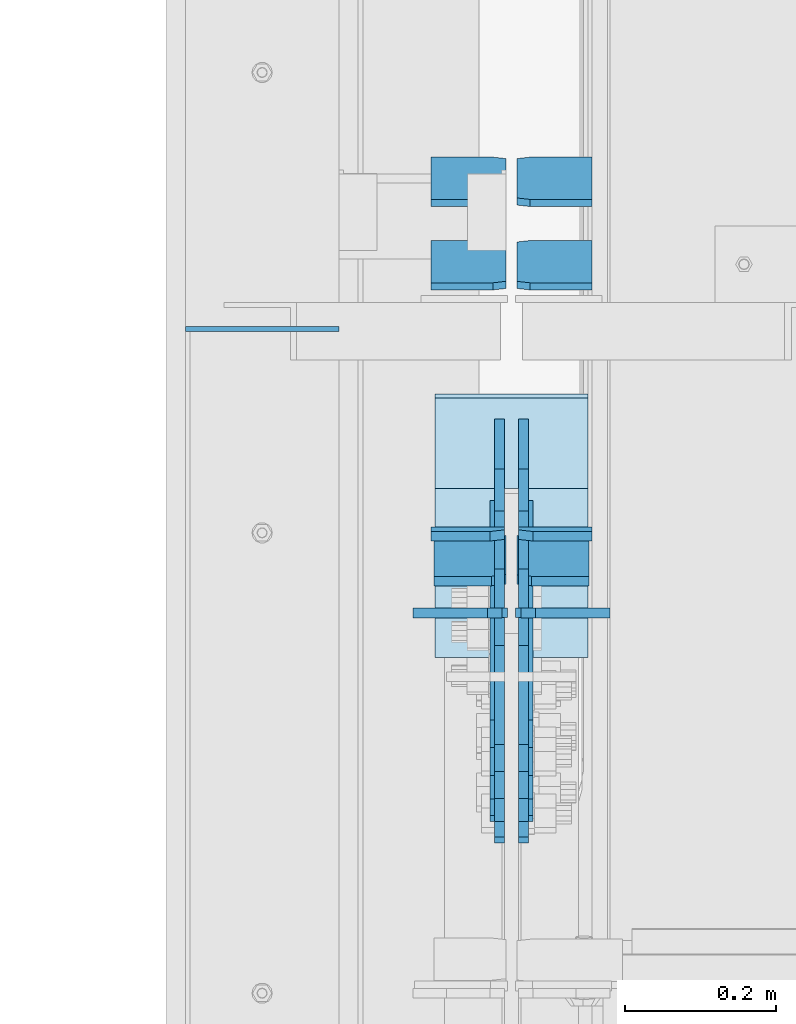
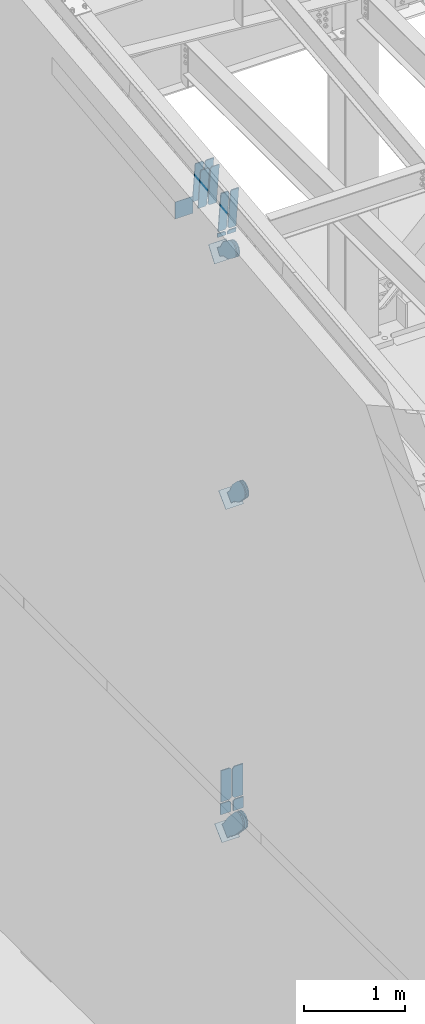
# One storey, part 1014 of 1179: 22 plates, 12 elements without a shape of their own.
"""IFC2X3 building model written with IfcOpenShell, lengths in millimetres."""

from ifc_helpers import new_model, si_unit, frame, origin_with_axes, place, context, subcontext, project, spatial, faceted_brep, material, type_object, element, aggregate, save


model = new_model("IFC2X3")

# Units and contexts
model_context = context("Model", 3, precision=1e-05, world=origin_with_axes())
body_context = subcontext(model_context, "Body", "Model", "MODEL_VIEW")
ifc_project = project(units=[si_unit("LENGTHUNIT", "METRE", prefix="MILLI"), si_unit("AREAUNIT", "SQUARE_METRE"), si_unit("VOLUMEUNIT", "CUBIC_METRE"), si_unit("MASSUNIT", "GRAM", prefix="KILO"), si_unit("TIMEUNIT", "SECOND"), si_unit("PLANEANGLEUNIT", "RADIAN"), si_unit("SOLIDANGLEUNIT", "STERADIAN"), si_unit("THERMODYNAMICTEMPERATUREUNIT", "DEGREE_CELSIUS"), si_unit("LUMINOUSINTENSITYUNIT", "LUMEN")], contexts=[model_context])

# Site, building, storey
site_placement = place(None, origin_with_axes())
site = spatial("IfcSite", under=ifc_project, at=site_placement, CompositionType="ELEMENT")
building_placement = place(site_placement, origin_with_axes())
building = spatial("IfcBuilding", under=site, at=building_placement, Name="Undefined", CompositionType="ELEMENT")
storey_placement = place(building_placement, origin_with_axes())
storey = spatial("IfcBuildingStorey", under=building, at=storey_placement, Name="Undefined", CompositionType="ELEMENT", Elevation=0.0)

# Assembly, plates
assembly_1_placement = place(storey_placement, origin_with_axes())
assembly_1 = element("IfcElementAssembly", 1, at=assembly_1_placement, inside=storey, Name="BEAM", AssemblyPlace="NOTDEFINED", PredefinedType="RIGID_FRAME")
ifc_material_1 = material(Name="STEEL/A572-GR.50")
plate_type_1 = type_object("IfcPlateType", PredefinedType="NOTDEFINED")
plate_1_placement = place(assembly_1_placement, frame((534.193750000002, 15956.040134361, 10522.6825112372), z_axis=(0.0, -0.112284087038017, 0.993676146336441), x_axis=(-1.0, 0.0, 0.0)))
plate_1 = element("IfcPlate", 2, at=plate_1_placement, type_object=plate_type_1, material=ifc_material_1, Name="PLATE", context=body_context, shape_type="Brep", body=[
    faceted_brep([(0.0, -6.34999999999854, 0.0), (0.0, -6.35000000019863, 498.474999998592), (0.0, 6.34999999979118, 498.474999998596), (0.0, 6.34999999999854, 0.0), (76.2000007629395, -6.35000000019863, 498.474999998592), (76.2000007629395, 6.34999999979118, 498.474999998596), (95.25, -6.350000000195, 479.425000761541), (95.25, 6.34999999980209, 479.425000761548), (95.25, -6.35000000000946, 19.0499992370496), (95.25, 6.34999999998399, 19.0499992370533), (76.2000007629395, -6.35000000000218, 0.0), (76.2000007629395, 6.34999999999491, 3.63797880709171e-12)], [[[0, 1, 2, 3]], [[1, 4, 5, 2]], [[4, 6, 7, 5]], [[6, 8, 9, 7]], [[8, 10, 11, 9]], [[10, 0, 3, 11]], [[5, 7, 9, 11, 3, 2]], [[10, 8, 6, 4, 1, 0]]]),
])
plate_2_placement = place(assembly_1_placement, frame((424.656250000002, 15956.040134361, 10522.6825112372), z_axis=(0.0, -0.112284087038017, 0.993676146336441), x_axis=(-1.0, 0.0, 0.0)))
plate_2 = element("IfcPlate", 3, at=plate_2_placement, type_object=plate_type_1, material=ifc_material_1, Name="PLATE", context=body_context, shape_type="Brep", body=[
    faceted_brep([(0.0, -6.35000000000036, 19.0499999999993), (0.0, -6.350000000195, 479.425000761541), (0.0, 6.34999999980209, 479.425000761548), (0.0, 6.35000000000036, 19.0499999999993), (19.0499992370605, -6.35000000019863, 498.474999998592), (19.0499992370605, 6.34999999979118, 498.474999998596), (95.25, -6.349999999793, 498.474999998598), (95.25, 6.35000000020045, 498.474999998592), (95.25, -6.34999999999309, 1.81898940354586e-12), (95.25, 6.34999999999854, -1.81898940354586e-12), (19.0500000000002, -6.35000000000036, 0.0), (19.0500000000002, 6.35000000000036, 0.0)], [[[0, 1, 2, 3]], [[1, 4, 5, 2]], [[4, 6, 7, 5]], [[6, 8, 9, 7]], [[8, 10, 11, 9]], [[3, 11, 10, 0]], [[5, 7, 9, 11, 3, 2]], [[10, 8, 6, 4, 1, 0]]]),
])

assembly_2_placement = place(storey_placement, origin_with_axes())
assembly_2 = element("IfcElementAssembly", 4, at=assembly_2_placement, inside=storey, Name="BEAM", AssemblyPlace="NOTDEFINED", PredefinedType="RIGID_FRAME")
plate_type_2 = type_object("IfcPlateType", PredefinedType="NOTDEFINED")
plate_3_placement = place(assembly_2_placement, frame((558.006250000002, 15857.8351561904, 3703.6375), z_axis=(0.0, 0.0, 1.0), x_axis=(-1.0, 0.0, 0.0)))
plate_3 = element("IfcPlate", 5, at=plate_3_placement, type_object=plate_type_2, material=ifc_material_1, Name="PLATE", context=body_context, shape_type="Brep", body=[
    faceted_brep([(0.0, -6.34999999999854, 0.0), (0.0, -6.35000000000036, 377.825012207031), (0.0, 6.35000000000036, 377.825012207031), (0.0, 6.34999999999854, 0.0), (98.4250011444092, -6.35000000000036, 377.825012207031), (98.4250011444092, 6.35000000000036, 377.825012207031), (120.650001525879, -6.35000000000036, 355.600011825562), (120.650001525879, 6.35000000000036, 355.600011825562), (120.650001525879, -6.35000000000036, 22.2250003814697), (120.650001525879, 6.35000000000036, 22.2250003814697), (98.4250011444092, -6.35000000000036, 0.0), (98.4250011444092, 6.35000000000036, 0.0)], [[[0, 1, 2, 3]], [[1, 4, 5, 2]], [[4, 6, 7, 5]], [[6, 8, 9, 7]], [[8, 10, 11, 9]], [[10, 0, 3, 11]], [[5, 7, 9, 11, 3, 2]], [[10, 8, 6, 4, 1, 0]]]),
])
plate_4_placement = place(assembly_2_placement, frame((426.243750000002, 15857.8351561904, 3703.6375), z_axis=(0.0, 0.0, 1.0), x_axis=(-1.0, 0.0, 0.0)))
plate_4 = element("IfcPlate", 6, at=plate_4_placement, type_object=plate_type_2, material=ifc_material_1, Name="PLATE", context=body_context, shape_type="Brep", body=[
    faceted_brep([(0.0, -6.34999999999854, 22.2250003814697), (0.0, -6.34999999999854, 355.600011825562), (0.0, 6.34999999999854, 355.600011825562), (0.0, 6.34999999999854, 22.2250003814697), (22.2250003814697, -6.34999999999854, 377.825012207031), (22.2250003814697, 6.34999999999854, 377.825012207031), (120.650001525879, -6.34999999999854, 377.825012207031), (120.650001525879, 6.34999999999854, 377.825012207031), (120.650001525879, -6.34999999999854, 0.0), (120.650001525879, 6.34999999999854, 0.0), (22.2250003814697, -6.34999999999854, 0.0), (22.2250003814697, 6.34999999999854, 0.0)], [[[0, 1, 2, 3]], [[1, 4, 5, 2]], [[4, 6, 7, 5]], [[6, 8, 9, 7]], [[8, 10, 11, 9]], [[10, 0, 3, 11]], [[5, 7, 9, 11, 3, 2]], [[10, 8, 6, 4, 1, 0]]]),
])

# Assembly, plate
assembly_3_placement = place(storey_placement, origin_with_axes())
assembly_3 = element("IfcElementAssembly", 7, at=assembly_3_placement, inside=storey, AssemblyPlace="NOTDEFINED", PredefinedType="RIGID_FRAME")
ifc_material_2 = material(Name="STEEL/A36")
plate_type_3 = type_object("IfcPlateType", PredefinedType="NOTDEFINED")
plate_5_placement = place(assembly_3_placement, frame((415.925000000002, 16048.2448473155, 10252.7845981471), z_axis=(0.0, -0.591856615182529, -0.80604326624858), x_axis=(0.0, 0.806043266248581, -0.591856615182529)))
plate_5 = element("IfcPlate", 8, at=plate_5_placement, type_object=plate_type_3, material=ifc_material_2, context=body_context, shape_type="Brep", body=[
    faceted_brep([(0.0, -6.34999999999854, 0.0), (-101.600000000211, -6.34999999999854, -44.6881937825565), (-101.600000000211, 6.34999999999854, -44.6881937825565), (0.0, 6.34999999999854, 0.0), (-246.684985848258, -6.34999999999854, -44.6881937827675), (-246.684985848258, 6.34999999999854, -44.6881937827675), (-281.313054102191, -6.34999999999854, -37.800242748639), (-281.313054102191, 6.34999999999854, -37.800242748639), (-310.669312868691, -6.34999999999854, -18.1850177516608), (-310.669312868691, 6.34999999999854, -18.1850177516608), (-330.284537865713, -6.34999999999854, 11.1712410148393), (-330.284537865713, 6.34999999999854, 11.1712410148393), (-337.172488899912, -6.34999999999854, 45.7993031647638), (-337.172488899912, 6.34999999999854, 45.7993031647638), (-330.284537865768, -6.34999999999854, 80.4273714187839), (-330.284537865768, 6.34999999999854, 80.4273714187839), (-310.669312868773, -6.34999999999854, 109.783630185371), (-310.669312868773, 6.34999999999854, 109.783630185371), (-281.313054102271, -6.34999999999854, 129.398855182466), (-281.313054102271, 6.34999999999854, 129.398855182466), (-246.684988899762, -6.34999999999854, 136.286806216707), (-246.684988899762, 6.34999999999854, 136.286806216707), (-101.600000000377, -6.34999999999854, 136.286806216911), (-101.600000000377, 6.34999999999854, 136.286806216911), (-8.18545231595635e-11, -6.34999999999854, 91.5986124346418), (-8.18545231595635e-11, 6.34999999999854, 91.5986124346418), (82.5500000001266, -6.34999999999854, 91.5986124347546), (82.5500000001266, 6.34999999999854, 91.5986124347546), (82.550000000203, -6.34999999999854, 1.2732925824821e-10), (82.550000000203, 6.34999999999854, 1.2732925824821e-10)], [[[0, 1, 2, 3]], [[1, 4, 5, 2]], [[4, 6, 7, 5]], [[6, 8, 9, 7]], [[8, 10, 11, 9]], [[10, 12, 13, 11]], [[12, 14, 15, 13]], [[14, 16, 17, 15]], [[16, 18, 19, 17]], [[18, 20, 21, 19]], [[20, 22, 23, 21]], [[22, 24, 25, 23]], [[24, 26, 27, 25]], [[26, 28, 29, 27]], [[28, 0, 3, 29]], [[5, 7, 9, 11, 13, 15, 17, 19, 21, 23, 25, 27, 29, 3, 2]], [[28, 26, 24, 22, 20, 18, 16, 14, 12, 10, 8, 6, 4, 1, 0]]]),
])
aggregate(assembly_3, [plate_5])

assembly_4_placement = place(storey_placement, origin_with_axes())
assembly_4 = element("IfcElementAssembly", 9, at=assembly_4_placement, inside=storey, AssemblyPlace="NOTDEFINED", PredefinedType="RIGID_FRAME")
plate_6_placement = place(assembly_4_placement, frame((447.675000000002, 16048.2448473155, 10252.7845981471), z_axis=(0.0, -0.591856615182529, -0.80604326624858), x_axis=(0.0, 0.806043266248581, -0.591856615182529)))
plate_6 = element("IfcPlate", 10, at=plate_6_placement, type_object=plate_type_3, material=ifc_material_2, context=body_context, shape_type="Brep", body=[
    faceted_brep([(0.0, -6.34999999999854, 0.0), (-101.600000000211, -6.34999999999854, -44.6881937825565), (-101.600000000211, 6.34999999999854, -44.6881937825565), (0.0, 6.34999999999854, 0.0), (-246.684985848258, -6.34999999999854, -44.6881937827675), (-246.684985848258, 6.34999999999854, -44.6881937827675), (-281.313054102191, -6.34999999999854, -37.800242748639), (-281.313054102191, 6.34999999999854, -37.800242748639), (-310.669312868691, -6.34999999999854, -18.1850177516608), (-310.669312868691, 6.34999999999854, -18.1850177516608), (-330.284537865713, -6.34999999999854, 11.1712410148393), (-330.284537865713, 6.34999999999854, 11.1712410148393), (-337.172488899912, -6.34999999999854, 45.7993031647638), (-337.172488899912, 6.34999999999854, 45.7993031647638), (-330.284537865768, -6.34999999999854, 80.4273714187839), (-330.284537865768, 6.34999999999854, 80.4273714187839), (-310.669312868773, -6.34999999999854, 109.783630185371), (-310.669312868773, 6.34999999999854, 109.783630185371), (-281.313054102271, -6.34999999999854, 129.398855182466), (-281.313054102271, 6.34999999999854, 129.398855182466), (-246.684988899762, -6.34999999999854, 136.286806216707), (-246.684988899762, 6.34999999999854, 136.286806216707), (-101.600000000377, -6.34999999999854, 136.286806216911), (-101.600000000377, 6.34999999999854, 136.286806216911), (-8.18545231595635e-11, -6.34999999999854, 91.5986124346418), (-8.18545231595635e-11, 6.34999999999854, 91.5986124346418), (82.5500000001266, -6.34999999999854, 91.5986124347546), (82.5500000001266, 6.34999999999854, 91.5986124347546), (82.550000000203, -6.34999999999854, 1.2732925824821e-10), (82.550000000203, 6.34999999999854, 1.2732925824821e-10)], [[[0, 1, 2, 3]], [[1, 4, 5, 2]], [[4, 6, 7, 5]], [[6, 8, 9, 7]], [[8, 10, 11, 9]], [[10, 12, 13, 11]], [[12, 14, 15, 13]], [[14, 16, 17, 15]], [[16, 18, 19, 17]], [[18, 20, 21, 19]], [[20, 22, 23, 21]], [[22, 24, 25, 23]], [[24, 26, 27, 25]], [[26, 28, 29, 27]], [[28, 0, 3, 29]], [[5, 7, 9, 11, 13, 15, 17, 19, 21, 23, 25, 27, 29, 3, 2]], [[28, 26, 24, 22, 20, 18, 16, 14, 12, 10, 8, 6, 4, 1, 0]]]),
])
aggregate(assembly_4, [plate_6])

assembly_5_placement = place(storey_placement, origin_with_axes())
assembly_5 = element("IfcElementAssembly", 11, at=assembly_5_placement, inside=storey, Name="BEAM", AssemblyPlace="NOTDEFINED", PredefinedType="RIGID_FRAME")
plate_type_4 = type_object("IfcPlateType", PredefinedType="NOTDEFINED")
plate_7_placement = place(assembly_5_placement, frame((0.0, 16233.775, 10824.825825947), z_axis=(0.0, 0.0, -1.0), x_axis=(1.0, 0.0, 0.0)))
plate_7 = element("IfcPlate", 12, at=plate_7_placement, type_object=plate_type_4, material=ifc_material_2, Name="CAP_PLATE", context=body_context, shape_type="Brep", body=[
    faceted_brep([(0.0, -3.17500000000109, 0.0), (0.0, -3.17499999999927, 204.492999998953), (0.0, 3.17499999999927, 204.492999998953), (0.0, 3.17500000000109, 7.27595761418343e-12), (203.199999999997, -3.17499999999927, 204.492999998953), (203.199999999997, 3.17499999999927, 204.492999998953), (203.199999999997, -3.17499999999927, 3.63797880709171e-12), (203.199999999997, 3.17499999999382, -3.63797880709171e-12)], [[[0, 1, 2, 3]], [[1, 4, 5, 2]], [[4, 6, 7, 5]], [[6, 0, 3, 7]], [[5, 7, 3, 2]], [[6, 4, 1, 0]]]),
])
aggregate(assembly_5, [plate_7])

assembly_6_placement = place(storey_placement, origin_with_axes())
assembly_6 = element("IfcElementAssembly", 13, at=assembly_6_placement, inside=storey, Name="Plate", AssemblyPlace="NOTDEFINED", PredefinedType="RIGID_FRAME")
plate_8_placement = place(assembly_6_placement, frame((330.200000000002, 16024.9852771183, 10086.9957610887), z_axis=(0.0, 0.591856615182528, 0.806043266248581), x_axis=(1.0, 0.0, 0.0)))
plate_8 = element("IfcPlate", 14, at=plate_8_placement, type_object=plate_type_4, material=ifc_material_2, Name="Plate", context=body_context, shape_type="Brep", body=[
    faceted_brep([(0.0, -3.17500000000109, 0.0), (0.0, -3.17500000000291, 203.200000000368), (0.0, 3.17499999998836, 203.200000000361), (0.0, 3.17500000000109, 7.27595761418343e-12), (203.199999999997, -3.17500000000291, 203.200000000368), (203.199999999997, 3.17499999998836, 203.200000000361), (203.199999999997, -3.17499999999927, 3.63797880709171e-12), (203.199999999997, 3.17499999999382, -3.63797880709171e-12)], [[[0, 1, 2, 3]], [[1, 4, 5, 2]], [[4, 6, 7, 5]], [[6, 0, 3, 7]], [[5, 7, 3, 2]], [[6, 4, 1, 0]]]),
])
aggregate(assembly_6, [plate_8])

assembly_7_placement = place(storey_placement, origin_with_axes())
assembly_7 = element("IfcElementAssembly", 15, at=assembly_7_placement, inside=storey, Name="Plate", AssemblyPlace="NOTDEFINED", PredefinedType="RIGID_FRAME")
plate_9_placement = place(assembly_7_placement, frame((330.200000000002, 15801.1352561728, 7258.01555805047), z_axis=(0.0, 0.71564233903776, 0.698466923036849), x_axis=(1.0, 0.0, 0.0)))
plate_9 = element("IfcPlate", 16, at=plate_9_placement, type_object=plate_type_4, material=ifc_material_2, Name="Plate", context=body_context, shape_type="Brep", body=[
    faceted_brep([(0.0, -3.17500000000109, 0.0), (0.0, -3.17500000000291, 203.200000000368), (0.0, 3.17499999998836, 203.200000000361), (0.0, 3.17500000000109, 7.27595761418343e-12), (203.199999999997, -3.17500000000291, 203.200000000368), (203.199999999997, 3.17499999998836, 203.200000000361), (203.199999999997, -3.17499999999927, 3.63797880709171e-12), (203.199999999997, 3.17499999999382, -3.63797880709171e-12)], [[[0, 1, 2, 3]], [[1, 4, 5, 2]], [[4, 6, 7, 5]], [[6, 0, 3, 7]], [[5, 7, 3, 2]], [[6, 4, 1, 0]]]),
])
aggregate(assembly_7, [plate_9])

assembly_8_placement = place(storey_placement, origin_with_axes())
assembly_8 = element("IfcElementAssembly", 17, at=assembly_8_placement, inside=storey, Name="Plate", AssemblyPlace="NOTDEFINED", PredefinedType="RIGID_FRAME")
plate_10_placement = place(assembly_8_placement, frame((330.200000000002, 15877.3775325798, 3189.63896334256), z_axis=(0.0, 0.727605443744036, 0.68599585875867), x_axis=(1.0, 0.0, 0.0)))
plate_10 = element("IfcPlate", 18, at=plate_10_placement, type_object=plate_type_4, material=ifc_material_2, Name="Plate", context=body_context, shape_type="Brep", body=[
    faceted_brep([(0.0, -3.17500000000109, 0.0), (0.0, -3.17500000000291, 203.200000000368), (0.0, 3.17499999998836, 203.200000000361), (0.0, 3.17500000000109, 7.27595761418343e-12), (203.199999999997, -3.17500000000291, 203.200000000368), (203.199999999997, 3.17499999998836, 203.200000000361), (203.199999999997, -3.17499999999927, 3.63797880709171e-12), (203.199999999997, 3.17499999999382, -3.63797880709171e-12)], [[[0, 1, 2, 3]], [[1, 4, 5, 2]], [[4, 6, 7, 5]], [[6, 0, 3, 7]], [[5, 7, 3, 2]], [[6, 4, 1, 0]]]),
])
aggregate(assembly_8, [plate_10])

# Plate
plate_type_5 = type_object("IfcPlateType", PredefinedType="NOTDEFINED")
plate_11_placement = place(assembly_1_placement, frame((422.275000000001, 15959.3331831468, 10497.4929739025), z_axis=(-1.0, 0.0, 0.0), x_axis=(0.0, 0.112284087038014, -0.993676146336441)))
plate_11 = element("IfcPlate", 19, at=plate_11_placement, type_object=plate_type_5, material=ifc_material_1, Name="PLATE", context=body_context, shape_type="Brep", body=[
    faceted_brep([(0.0, 6.35000000000036, 19.0499999999993), (19.0500000000002, 6.35000000000036, 0.0), (19.0500000000002, -6.35000000000036, 0.0), (0.0, -6.35000000000036, 19.0499999999993), (0.0, -6.35000000000036, 96.8374999999978), (0.0, 6.35000000000036, 96.8374999999978), (50.799999999721, -6.34999999997308, 96.8375), (50.7999999997155, 6.35000000001673, 96.8375), (50.799999999721, -6.34999999997308, 0.0), (50.7999999997155, 6.35000000001673, 0.0)], [[[0, 1, 2, 3]], [[4, 5, 0, 3]], [[4, 6, 7, 5]], [[6, 8, 9, 7]], [[9, 8, 2, 1]], [[5, 7, 9, 1, 0]], [[8, 6, 4, 3, 2]]]),
])

plate_12_placement = place(assembly_1_placement, frame((441.325000000003, 15959.3331831468, 10497.4929739025), z_axis=(1.0, 0.0, 0.0), x_axis=(0.0, 0.112284087038014, -0.993676146336441)))
plate_12 = element("IfcPlate", 20, at=plate_12_placement, type_object=plate_type_5, material=ifc_material_1, Name="PLATE", context=body_context, shape_type="Brep", body=[
    faceted_brep([(0.0, 6.35000000000036, 19.0499999999993), (19.0500000000002, 6.35000000000036, 0.0), (19.0500000000002, -6.35000000000036, 0.0), (0.0, -6.35000000000036, 19.0499999999993), (0.0, -6.35000000000036, 96.8374999999978), (0.0, 6.35000000000036, 96.8374999999978), (50.799999999721, -6.34999999997308, 96.8375), (50.7999999997155, 6.35000000001673, 96.8375), (50.799999999721, -6.34999999997308, 0.0), (50.7999999997155, 6.35000000001673, 0.0)], [[[0, 1, 2, 3]], [[4, 5, 0, 3]], [[4, 6, 7, 5]], [[6, 8, 9, 7]], [[9, 8, 2, 1]], [[5, 7, 9, 1, 0]], [[8, 6, 4, 3, 2]]]),
])

plate_type_6 = type_object("IfcPlateType", PredefinedType="NOTDEFINED")
plate_13_placement = place(assembly_2_placement, frame((419.100000000002, 15857.7897419842, 3549.97993849189), z_axis=(-1.0, 0.0, 0.0), x_axis=(0.0, 0.0, 1.0)))
plate_13 = element("IfcPlate", 21, at=plate_13_placement, type_object=plate_type_6, material=ifc_material_1, Name="PLATE", context=body_context, shape_type="Brep", body=[
    faceted_brep([(0.0, -6.34999999999854, 0.0), (0.0, -6.35000000000036, 117.474999999999), (0.0, 6.35000000000036, 117.474999999999), (0.0, 6.34999999999854, 0.0), (133.020061565272, -6.35000000000036, 117.474999999999), (133.020061565272, 6.35000000000036, 117.474999999999), (133.020061565272, -6.35000000000036, 19.0499992370605), (133.020061565272, 6.35000000000036, 19.0499992370605), (113.970062328212, -6.35000000000036, 0.0), (113.970062328212, 6.35000000000036, 0.0)], [[[0, 1, 2, 3]], [[1, 4, 5, 2]], [[4, 6, 7, 5]], [[6, 8, 9, 7]], [[8, 0, 3, 9]], [[5, 7, 9, 3, 2]], [[8, 6, 4, 1, 0]]]),
])

plate_14_placement = place(assembly_2_placement, frame((444.500000000002, 15857.7897419842, 3549.97993849189), z_axis=(1.0, 0.0, 0.0), x_axis=(0.0, 0.0, 1.0)))
plate_14 = element("IfcPlate", 22, at=plate_14_placement, type_object=plate_type_6, material=ifc_material_1, Name="PLATE", context=body_context, shape_type="Brep", body=[
    faceted_brep([(0.0, -6.34999999999854, 0.0), (0.0, -6.35000000000036, 117.474999999999), (0.0, 6.35000000000036, 117.474999999999), (0.0, 6.34999999999854, 0.0), (133.020061565272, -6.35000000000036, 117.474999999999), (133.020061565272, 6.35000000000036, 117.474999999999), (133.020061565272, -6.35000000000036, 19.0499992370605), (133.020061565272, 6.35000000000036, 19.0499992370605), (113.970062328212, -6.35000000000036, 0.0), (113.970062328212, 6.35000000000036, 0.0)], [[[0, 1, 2, 3]], [[1, 4, 5, 2]], [[4, 6, 7, 5]], [[6, 8, 9, 7]], [[8, 0, 3, 9]], [[5, 7, 9, 3, 2]], [[8, 6, 4, 1, 0]]]),
])

aggregate(assembly_2, [plate_3, plate_4, plate_13, plate_14])

plate_type_7 = type_object("IfcPlateType", PredefinedType="NOTDEFINED")
plate_15_placement = place(assembly_1_placement, frame((538.162500000002, 16346.2342144593, 10566.7739249366), z_axis=(0.0, -0.112284087038017, 0.993676146336441), x_axis=(-1.0, 0.0, 0.0)))
plate_15 = element("IfcPlate", 23, at=plate_15_placement, type_object=plate_type_7, material=ifc_material_2, Name="PLATE", context=body_context, shape_type="Brep", body=[
    faceted_brep([(0.0, -4.76249999999709, 0.0), (0.0, -4.76250000020082, 498.474999998594), (0.0, 4.76249999979336, 498.474999998596), (0.0, 4.76249999999709, 0.0), (81.7562503814697, -4.76250000020082, 498.474999998594), (81.7562503814697, 4.76249999979336, 498.474999998596), (99.21875, -4.76250000019354, 481.012500380073), (99.21875, 4.76249999980064, 481.012500380079), (99.21875, -4.76250000000437, 17.4624996185212), (99.21875, 4.76249999998981, 17.4624996185248), (81.7562503814697, -4.76250000000073, 0.0), (81.7562503814697, 4.76249999999709, 3.63797880709171e-12)], [[[0, 1, 2, 3]], [[1, 4, 5, 2]], [[4, 6, 7, 5]], [[6, 8, 9, 7]], [[8, 10, 11, 9]], [[10, 0, 3, 11]], [[5, 7, 9, 11, 3, 2]], [[10, 8, 6, 4, 1, 0]]]),
])

plate_16_placement = place(assembly_1_placement, frame((424.656250000002, 16346.2342144593, 10566.7739249366), z_axis=(0.0, -0.112284087038017, 0.993676146336441), x_axis=(-1.0, 0.0, 0.0)))
plate_16 = element("IfcPlate", 24, at=plate_16_placement, type_object=plate_type_7, material=ifc_material_2, Name="PLATE", context=body_context, shape_type="Brep", body=[
    faceted_brep([(-1.81898940354586e-12, -4.76249999999345, 17.4624996185303), (0.0, -4.76250000019354, 481.012500380073), (0.0, 4.76249999980064, 481.012500380079), (1.81898940354586e-12, 4.76250000000073, 17.4624996185303), (17.4624996185303, -4.76250000020082, 498.474999998594), (17.4624996185303, 4.76249999979336, 498.474999998596), (99.2187497618652, -4.76249999998072, 498.475), (99.2187499999927, 4.76250000001892, 498.475), (99.21875, -4.76250000000073, 0.0), (99.21875, 4.76249999999709, 3.63797880709171e-12), (17.4624996185157, -4.76250000000073, 0.0), (17.4624996185212, 4.76249999999345, 0.0)], [[[0, 1, 2, 3]], [[1, 4, 5, 2]], [[4, 6, 7, 5]], [[6, 8, 9, 7]], [[8, 10, 11, 9]], [[10, 0, 3, 11]], [[5, 7, 9, 11, 3, 2]], [[10, 8, 6, 4, 1, 0]]]),
])

plate_17_placement = place(assembly_1_placement, frame((538.162500000002, 16456.6564762209, 10579.2514941086), z_axis=(0.0, -0.112284087038017, 0.993676146336441), x_axis=(-1.0, 0.0, 0.0)))
plate_17 = element("IfcPlate", 25, at=plate_17_placement, type_object=plate_type_7, material=ifc_material_2, Name="PLATE", context=body_context, shape_type="Brep", body=[
    faceted_brep([(0.0, -4.76249999999709, 0.0), (0.0, -4.76250000020082, 498.474999998594), (0.0, 4.76249999979336, 498.474999998596), (0.0, 4.76249999999709, 0.0), (81.7562503814697, -4.76250000020082, 498.474999998594), (81.7562503814697, 4.76249999979336, 498.474999998596), (99.21875, -4.76250000019354, 481.012500380073), (99.21875, 4.76249999980064, 481.012500380079), (99.21875, -4.76250000000437, 17.4624996185212), (99.21875, 4.76249999998981, 17.4624996185248), (81.7562503814697, -4.76250000000073, 0.0), (81.7562503814697, 4.76249999999709, 3.63797880709171e-12)], [[[0, 1, 2, 3]], [[1, 4, 5, 2]], [[4, 6, 7, 5]], [[6, 8, 9, 7]], [[8, 10, 11, 9]], [[10, 0, 3, 11]], [[5, 7, 9, 11, 3, 2]], [[10, 8, 6, 4, 1, 0]]]),
])

plate_18_placement = place(assembly_1_placement, frame((424.656250000002, 16456.6564762209, 10579.2514941086), z_axis=(0.0, -0.112284087038017, 0.993676146336441), x_axis=(-1.0, 0.0, 0.0)))
plate_18 = element("IfcPlate", 26, at=plate_18_placement, type_object=plate_type_7, material=ifc_material_2, Name="PLATE", context=body_context, shape_type="Brep", body=[
    faceted_brep([(-1.81898940354586e-12, -4.76249999999345, 17.4624996185303), (0.0, -4.76250000019354, 481.012500380073), (0.0, 4.76249999980064, 481.012500380079), (1.81898940354586e-12, 4.76250000000073, 17.4624996185303), (17.4624996185303, -4.76250000020082, 498.474999998594), (17.4624996185303, 4.76249999979336, 498.474999998596), (99.2187497618652, -4.76249999998072, 498.475), (99.2187499999927, 4.76250000001892, 498.475), (99.21875, -4.76250000000073, 0.0), (99.21875, 4.76249999999709, 3.63797880709171e-12), (17.4624996185157, -4.76250000000073, 0.0), (17.4624996185212, 4.76249999999345, 0.0)], [[[0, 1, 2, 3]], [[1, 4, 5, 2]], [[4, 6, 7, 5]], [[6, 8, 9, 7]], [[8, 10, 11, 9]], [[10, 0, 3, 11]], [[5, 7, 9, 11, 3, 2]], [[10, 8, 6, 4, 1, 0]]]),
])

aggregate(assembly_1, [plate_1, plate_2, plate_11, plate_12, plate_15, plate_16, plate_17, plate_18])

# Assembly, plate
assembly_9_placement = place(storey_placement, origin_with_axes())
assembly_9 = element("IfcElementAssembly", 27, at=assembly_9_placement, inside=storey, AssemblyPlace="NOTDEFINED", PredefinedType="RIGID_FRAME")
plate_type_8 = type_object("IfcPlateType", PredefinedType="NOTDEFINED")
plate_19_placement = place(assembly_9_placement, frame((415.925000000002, 15858.5458489471, 7424.96263980966), z_axis=(0.0, -0.715642339037757, -0.698466923036852), x_axis=(0.0, 0.698466923036852, -0.715642339037758)))
plate_19 = element("IfcPlate", 28, at=plate_19_placement, type_object=plate_type_8, material=ifc_material_2, context=body_context, shape_type="Brep", body=[
    faceted_brep([(0.0, -6.34999999999854, 0.0), (-101.599999999963, -6.34999999999854, -37.5700345970108), (-101.599999999963, 6.34999999999854, -37.5700345970108), (0.0, 6.34999999999854, 0.0), (-245.369242323884, -6.34999999999854, -37.5700345970945), (-245.369242323884, 6.34999999999854, -37.5700345970945), (-281.212328723803, -6.34999999999854, -30.4404014271258), (-281.212328723803, 6.34999999999854, -30.4404014271258), (-311.598630137756, -6.34999999999854, -10.1369239370142), (-311.598630137756, 6.34999999999854, -10.1369239370142), (-331.902107627997, -6.34999999999854, 20.24937747687), (-331.902107627997, 6.34999999999854, 20.24937747687), (-339.031740798124, -6.34999999999854, 56.0924669287269), (-339.031740798124, 6.34999999999854, 56.0924669287269), (-331.902107628228, -6.34999999999854, 91.9355533287926), (-331.902107628228, 6.34999999999854, 91.9355533287926), (-311.598630138099, -6.34999999999854, 122.321854742866), (-311.598630138099, 6.34999999999854, 122.321854742866), (-281.212328724136, -6.34999999999854, 142.625332233139), (-281.212328724136, 6.34999999999854, 142.625332233139), (-245.36924079839, -6.34999999999854, 149.754965403199), (-245.36924079839, 6.34999999999854, 149.754965403199), (-101.600000000685, -6.34999999999854, 149.75496540329), (-101.600000000685, 6.34999999999854, 149.75496540329), (-4.35647962149233e-10, -6.34999999999854, 112.184930806416), (-4.35647962149233e-10, 6.34999999999854, 112.184930806416), (82.5499999996491, -6.34999999999854, 112.184930806461), (82.5499999996491, 6.34999999999854, 112.184930806461), (82.550000000203, -6.34999999999854, 1.2732925824821e-10), (82.550000000203, 6.34999999999854, 1.2732925824821e-10)], [[[0, 1, 2, 3]], [[1, 4, 5, 2]], [[4, 6, 7, 5]], [[6, 8, 9, 7]], [[8, 10, 11, 9]], [[10, 12, 13, 11]], [[12, 14, 15, 13]], [[14, 16, 17, 15]], [[16, 18, 19, 17]], [[18, 20, 21, 19]], [[20, 22, 23, 21]], [[22, 24, 25, 23]], [[24, 26, 27, 25]], [[26, 28, 29, 27]], [[28, 0, 3, 29]], [[5, 7, 9, 11, 13, 15, 17, 19, 21, 23, 25, 27, 29, 3, 2]], [[28, 26, 24, 22, 20, 18, 16, 14, 12, 10, 8, 6, 4, 1, 0]]]),
])
aggregate(assembly_9, [plate_19])

assembly_10_placement = place(storey_placement, origin_with_axes())
assembly_10 = element("IfcElementAssembly", 29, at=assembly_10_placement, inside=storey, AssemblyPlace="NOTDEFINED", PredefinedType="RIGID_FRAME")
plate_20_placement = place(assembly_10_placement, frame((447.675000000002, 15858.5458489471, 7424.96263980966), z_axis=(0.0, -0.715642339037757, -0.698466923036852), x_axis=(0.0, 0.698466923036852, -0.715642339037758)))
plate_20 = element("IfcPlate", 30, at=plate_20_placement, type_object=plate_type_8, material=ifc_material_2, context=body_context, shape_type="Brep", body=[
    faceted_brep([(0.0, -6.34999999999854, 0.0), (-101.599999999963, -6.34999999999854, -37.5700345970108), (-101.599999999963, 6.34999999999854, -37.5700345970108), (0.0, 6.34999999999854, 0.0), (-245.369242323884, -6.34999999999854, -37.5700345970945), (-245.369242323884, 6.34999999999854, -37.5700345970945), (-281.212328723803, -6.34999999999854, -30.4404014271258), (-281.212328723803, 6.34999999999854, -30.4404014271258), (-311.598630137756, -6.34999999999854, -10.1369239370142), (-311.598630137756, 6.34999999999854, -10.1369239370142), (-331.902107627997, -6.34999999999854, 20.24937747687), (-331.902107627997, 6.34999999999854, 20.24937747687), (-339.031740798124, -6.34999999999854, 56.0924669287269), (-339.031740798124, 6.34999999999854, 56.0924669287269), (-331.902107628228, -6.34999999999854, 91.9355533287926), (-331.902107628228, 6.34999999999854, 91.9355533287926), (-311.598630138099, -6.34999999999854, 122.321854742866), (-311.598630138099, 6.34999999999854, 122.321854742866), (-281.212328724136, -6.34999999999854, 142.625332233139), (-281.212328724136, 6.34999999999854, 142.625332233139), (-245.36924079839, -6.34999999999854, 149.754965403199), (-245.36924079839, 6.34999999999854, 149.754965403199), (-101.600000000685, -6.34999999999854, 149.75496540329), (-101.600000000685, 6.34999999999854, 149.75496540329), (-4.35647962149233e-10, -6.34999999999854, 112.184930806416), (-4.35647962149233e-10, 6.34999999999854, 112.184930806416), (82.5499999996491, -6.34999999999854, 112.184930806461), (82.5499999996491, 6.34999999999854, 112.184930806461), (82.550000000203, -6.34999999999854, 1.2732925824821e-10), (82.550000000203, 6.34999999999854, 1.2732925824821e-10)], [[[0, 1, 2, 3]], [[1, 4, 5, 2]], [[4, 6, 7, 5]], [[6, 8, 9, 7]], [[8, 10, 11, 9]], [[10, 12, 13, 11]], [[12, 14, 15, 13]], [[14, 16, 17, 15]], [[16, 18, 19, 17]], [[18, 20, 21, 19]], [[20, 22, 23, 21]], [[22, 24, 25, 23]], [[24, 26, 27, 25]], [[26, 28, 29, 27]], [[28, 0, 3, 29]], [[5, 7, 9, 11, 13, 15, 17, 19, 21, 23, 25, 27, 29, 3, 2]], [[28, 26, 24, 22, 20, 18, 16, 14, 12, 10, 8, 6, 4, 1, 0]]]),
])
aggregate(assembly_10, [plate_20])

assembly_11_placement = place(storey_placement, origin_with_axes())
assembly_11 = element("IfcElementAssembly", 31, at=assembly_11_placement, inside=storey, AssemblyPlace="NOTDEFINED", PredefinedType="RIGID_FRAME")
plate_type_9 = type_object("IfcPlateType", PredefinedType="NOTDEFINED")
plate_21_placement = place(assembly_11_placement, frame((411.162500000002, 15950.2957051354, 3367.47788073479), z_axis=(0.0, -0.727605443744034, -0.685995858758672), x_axis=(0.0, 0.685995858758672, -0.727605443744034)))
plate_21 = element("IfcPlate", 32, at=plate_21_placement, type_object=plate_type_9, material=ifc_material_2, context=body_context, shape_type="Brep", body=[
    faceted_brep([(0.0, -7.9375, 0.0), (-101.600000000497, -7.9375, -21.7975798445477), (-101.600000000497, 7.9375, -21.7975798445477), (0.0, 7.9375, 0.0), (-320.921138851689, -7.9375, -21.7975798443877), (-320.921138851689, 7.9375, -21.7975798443877), (-357.371735784433, -7.9375, -14.5471053160727), (-357.371735784433, 7.9375, -14.5471053160727), (-388.273059759649, -7.9375, 6.10049924760824), (-388.273059759649, 7.9375, 6.10049924760824), (-408.920664323319, -7.9375, 37.0018232228431), (-408.920664323319, 7.9375, 37.0018232228431), (-416.171138851623, -7.9375, 73.4524201546446), (-416.171138851623, 7.9375, 73.4524201546446), (-408.920664323337, -7.9375, 109.903017087447), (-408.920664323337, 7.9375, 109.903017087447), (-388.273059759656, -7.9375, 140.804341062707), (-388.273059759656, 7.9375, 140.804341062707), (-357.3717357844, -7.9375, 161.451945626395), (-357.3717357844, 7.9375, 161.451945626395), (-320.921138851201, -7.9375, 168.702420154674), (-320.921138851201, 7.9375, 168.702420154674), (-101.600000000592, -7.9375, 168.702420154521), (-101.600000000592, 7.9375, 168.702420154521), (-8.00355337560177e-11, -7.9375, 146.904840309817), (-8.00355337560177e-11, 7.9375, 146.904840309817), (82.5499999998137, -7.9375, 146.90484031055), (82.5499999998137, 7.9375, 146.90484031055), (82.5500000000975, -7.9375, -6.91215973347425e-11), (82.5500000000975, 7.9375, -6.91215973347425e-11)], [[[0, 1, 2, 3]], [[1, 4, 5, 2]], [[4, 6, 7, 5]], [[6, 8, 9, 7]], [[8, 10, 11, 9]], [[10, 12, 13, 11]], [[12, 14, 15, 13]], [[14, 16, 17, 15]], [[16, 18, 19, 17]], [[18, 20, 21, 19]], [[20, 22, 23, 21]], [[22, 24, 25, 23]], [[24, 26, 27, 25]], [[26, 28, 29, 27]], [[28, 0, 3, 29]], [[5, 7, 9, 11, 13, 15, 17, 19, 21, 23, 25, 27, 29, 3, 2]], [[28, 26, 24, 22, 20, 18, 16, 14, 12, 10, 8, 6, 4, 1, 0]]]),
])
aggregate(assembly_11, [plate_21])

assembly_12_placement = place(storey_placement, origin_with_axes())
assembly_12 = element("IfcElementAssembly", 33, at=assembly_12_placement, inside=storey, AssemblyPlace="NOTDEFINED", PredefinedType="RIGID_FRAME")
plate_22_placement = place(assembly_12_placement, frame((452.437500000002, 15950.2957051354, 3367.47788073479), z_axis=(0.0, -0.727605443744034, -0.685995858758672), x_axis=(0.0, 0.685995858758672, -0.727605443744034)))
plate_22 = element("IfcPlate", 34, at=plate_22_placement, type_object=plate_type_9, material=ifc_material_2, context=body_context, shape_type="Brep", body=[
    faceted_brep([(0.0, -7.9375, 0.0), (-101.600000000497, -7.9375, -21.7975798445477), (-101.600000000497, 7.9375, -21.7975798445477), (0.0, 7.9375, 0.0), (-320.921138851689, -7.9375, -21.7975798443877), (-320.921138851689, 7.9375, -21.7975798443877), (-357.371735784433, -7.9375, -14.5471053160727), (-357.371735784433, 7.9375, -14.5471053160727), (-388.273059759649, -7.9375, 6.10049924760824), (-388.273059759649, 7.9375, 6.10049924760824), (-408.920664323319, -7.9375, 37.0018232228431), (-408.920664323319, 7.9375, 37.0018232228431), (-416.171138851623, -7.9375, 73.4524201546446), (-416.171138851623, 7.9375, 73.4524201546446), (-408.920664323337, -7.9375, 109.903017087447), (-408.920664323337, 7.9375, 109.903017087447), (-388.273059759656, -7.9375, 140.804341062707), (-388.273059759656, 7.9375, 140.804341062707), (-357.3717357844, -7.9375, 161.451945626395), (-357.3717357844, 7.9375, 161.451945626395), (-320.921138851201, -7.9375, 168.702420154674), (-320.921138851201, 7.9375, 168.702420154674), (-101.600000000592, -7.9375, 168.702420154521), (-101.600000000592, 7.9375, 168.702420154521), (-8.00355337560177e-11, -7.9375, 146.904840309817), (-8.00355337560177e-11, 7.9375, 146.904840309817), (82.5499999998137, -7.9375, 146.90484031055), (82.5499999998137, 7.9375, 146.90484031055), (82.5500000000975, -7.9375, -6.91215973347425e-11), (82.5500000000975, 7.9375, -6.91215973347425e-11)], [[[0, 1, 2, 3]], [[1, 4, 5, 2]], [[4, 6, 7, 5]], [[6, 8, 9, 7]], [[8, 10, 11, 9]], [[10, 12, 13, 11]], [[12, 14, 15, 13]], [[14, 16, 17, 15]], [[16, 18, 19, 17]], [[18, 20, 21, 19]], [[20, 22, 23, 21]], [[22, 24, 25, 23]], [[24, 26, 27, 25]], [[26, 28, 29, 27]], [[28, 0, 3, 29]], [[5, 7, 9, 11, 13, 15, 17, 19, 21, 23, 25, 27, 29, 3, 2]], [[28, 26, 24, 22, 20, 18, 16, 14, 12, 10, 8, 6, 4, 1, 0]]]),
])
aggregate(assembly_12, [plate_22])

save(model, "model.ifc")
